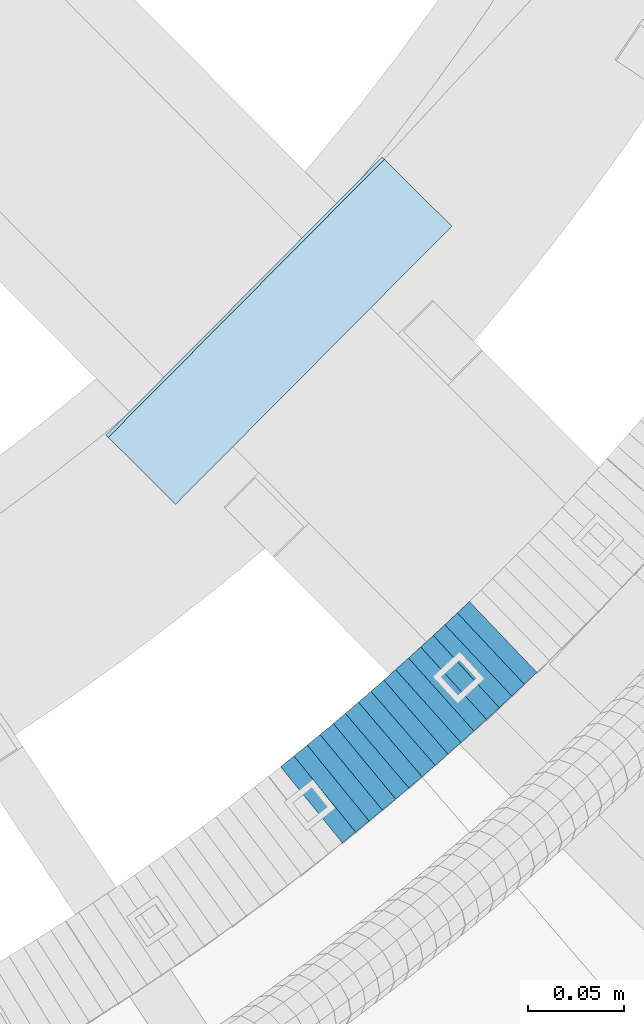
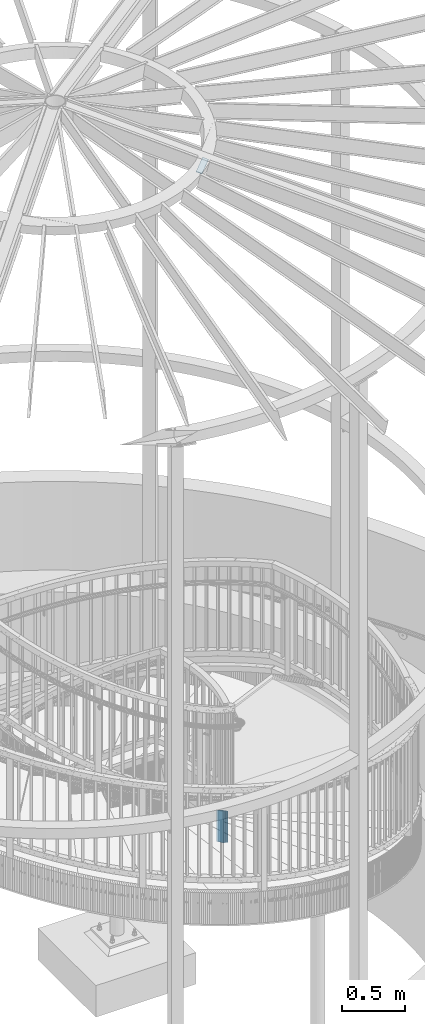
# One storey, part 889 of 975: 16 plates.
"""IFC2X3 building model written with IfcOpenShell, lengths in millimetres."""

import ifcopenshell
import ifcopenshell.guid

model = None  # the IFC model being written
_history = None  # IfcOwnerHistory: only IFC2X3 demands one
_inside = {}  # id of a spatial element -> (the spatial element, [elements in it])
_under = {}  # id of a project, library or spatial element -> (it, [spatial elements below it])
_declared = {}  # id of a project -> (the project, [libraries it declares])
_typed = {}  # id of a type object -> (the type object, [elements of that type])
_made_of = {}  # id of a material, layer set ... -> (it, [elements and type objects made of it])


def new_model(schema):
    """Start an empty IFC model of exactly this schema.

    Asked for "IFC4X3", IfcOpenShell would pick the latest addendum, in which some entities
    have other attributes; the version numbers below select the first issue.
    IFC2X3 requires an IfcOwnerHistory on every rooted entity: one is made here for all.
    """
    global model, _history
    if schema == "IFC4X3":
        model = ifcopenshell.file(schema_version=(4, 3, 0, 0))
    else:
        model = ifcopenshell.file(schema=schema)
    _inside.clear()
    _under.clear()
    _declared.clear()
    _typed.clear()
    _made_of.clear()
    _history = None
    if model.schema == "IFC2X3":
        org = make("IfcOrganization", Name="unknown")
        user = make(
            "IfcPersonAndOrganization",
            ThePerson=make("IfcPerson", FamilyName="unknown"),
            TheOrganization=org,
        )
        app = make(
            "IfcApplication",
            ApplicationDeveloper=org,
            Version="unknown",
            ApplicationFullName="unknown",
            ApplicationIdentifier="unknown",
        )
        _history = make(
            "IfcOwnerHistory",
            OwningUser=user,
            OwningApplication=app,
            ChangeAction="ADDED",
            CreationDate=0,
        )
    return model


def make(cls, **values):
    """One entity of the class cls with the attributes given. An attribute that is None is left unset."""
    return model.create_entity(
        cls, **{name: value for name, value in values.items() if value is not None}
    )


def rooted(cls, **values):
    """An entity with a GlobalId (a new one), such as an element, a storey or a relation."""
    return make(cls, GlobalId=ifcopenshell.guid.new(), OwnerHistory=_history, **values)


def si_unit(unit_type, name, prefix=None):
    """IfcSIUnit, for example si_unit("LENGTHUNIT", "METRE", prefix="MILLI")."""
    return make("IfcSIUnit", UnitType=unit_type, Prefix=prefix, Name=name)


def assignment(units):
    """IfcUnitAssignment: the units of a project."""
    return None if units is None else make("IfcUnitAssignment", Units=units)


def point(xyz):
    """IfcCartesianPoint."""
    return None if xyz is None else make("IfcCartesianPoint", Coordinates=xyz)


def direction(xyz):
    """IfcDirection."""
    return None if xyz is None else make("IfcDirection", DirectionRatios=xyz)


def frame(location, z_axis=None, x_axis=None):
    """IfcAxis2Placement3D, a coordinate frame: its origin and axes. An axis left out is left unset."""
    return make(
        "IfcAxis2Placement3D",
        Location=point(location),
        Axis=direction(z_axis),
        RefDirection=direction(x_axis),
    )


def origin_with_axes():
    """The frame at (0, 0, 0) with the z axis (0, 0, 1) and the x axis (1, 0, 0) written out."""
    return frame((0.0, 0.0, 0.0), z_axis=(0.0, 0.0, 1.0), x_axis=(1.0, 0.0, 0.0))


def place(relative_to, where):
    """IfcLocalPlacement: puts the frame where relative to a parent placement (None: the world)."""
    return make(
        "IfcLocalPlacement", PlacementRelTo=relative_to, RelativePlacement=where
    )


def context(
    kind, dimensions, precision=None, world=None, true_north=None, identifier=None
):
    """IfcGeometricRepresentationContext, for example the 3D "Model" context."""
    return make(
        "IfcGeometricRepresentationContext",
        ContextIdentifier=identifier,
        ContextType=kind,
        CoordinateSpaceDimension=dimensions,
        Precision=precision,
        WorldCoordinateSystem=world,
        TrueNorth=true_north,
    )


def subcontext(parent, identifier, kind, view, scale=None):
    """IfcGeometricRepresentationSubContext, for example "Body" below "Model"."""
    return make(
        "IfcGeometricRepresentationSubContext",
        ContextIdentifier=identifier,
        ContextType=kind,
        ParentContext=parent,
        TargetScale=scale,
        TargetView=view,
    )


def project(units=None, contexts=None):
    """IfcProject with its units and contexts."""
    return rooted(
        "IfcProject",
        Name="project",
        RepresentationContexts=contexts,
        UnitsInContext=assignment(units),
    )


def spatial(cls, under=None, at=None, **own):
    """A site, building, storey or space (cls), placed at a placement, below another one or the project."""
    s = rooted(cls, ObjectPlacement=at, **own)
    if under is not None:
        _under.setdefault(under.id(), (under, []))[1].append(s)
    return s


def faces_of(points, faces, orient=None, outer=None):
    """IfcFace entities. A face is a list of loops; a loop is a list of indices into points, from 0.

    orient and outer hold one flag for each loop. By default every Orientation is true, the
    first loop of a face is its IfcFaceOuterBound and the others are IfcFaceBound.
    """
    made = []
    for i, loops in enumerate(faces):
        bounds = []
        for j, loop in enumerate(loops):
            is_outer = j == 0 if outer is None else outer[i][j]
            bounds.append(
                make(
                    "IfcFaceOuterBound" if is_outer else "IfcFaceBound",
                    Bound=make("IfcPolyLoop", Polygon=[points[k] for k in loop]),
                    Orientation=True if orient is None else orient[i][j],
                )
            )
        made.append(make("IfcFace", Bounds=bounds))
    return made


def faceted_brep(points, faces, orient=None, outer=None, voids=None):
    """IfcFacetedBrep: a solid bounded by flat faces; with voids (closed shells), ...WithVoids."""
    shared = [point(p) for p in points]
    hull = make("IfcClosedShell", CfsFaces=faces_of(shared, faces, orient, outer))
    if voids is None:
        return make("IfcFacetedBrep", Outer=hull)
    return make(
        "IfcFacetedBrepWithVoids",
        Outer=hull,
        Voids=[
            make(cls, CfsFaces=faces_of(shared, fs, o, b)) for cls, fs, o, b in voids
        ],
    )


def shape(context_of_items, identifier, shape_type, items):
    """IfcShapeRepresentation: the items that make up one representation, for example the "Body"."""
    return make(
        "IfcShapeRepresentation",
        ContextOfItems=context_of_items,
        RepresentationIdentifier=identifier,
        RepresentationType=shape_type,
        Items=items,
    )


def material(Name=None, Category=None):
    """IfcMaterial."""
    return make("IfcMaterial", Name=Name, Category=Category)


def made_of(thing, what):
    """Note that an element or type object is made of a material, layer set ...; save() writes the relation."""
    if what is not None:
        _made_of.setdefault(what.id(), (what, []))[1].append(thing)
    return thing


def type_object(cls, material=None, **own):
    """A type object (cls), such as IfcWallType, which elements share."""
    return made_of(rooted(cls, **own), material)


def element(
    cls,
    number,
    at=None,
    inside=None,
    cuts=None,
    type_object=None,
    material=None,
    context=None,
    identifier="Body",
    shape_type=None,
    held_by="IfcProductDefinitionShape",
    body=None,
    shapes=None,
    **own,
):
    """One element of the class cls, such as IfcWall. Its Tag is "e" and its number.

    at: its placement. inside: the storey or other place that contains it. cuts: it is an
    opening in that element (IfcRelVoidsElement). A single representation is given by context,
    identifier, shape_type and body (its items); several are given by shapes. held_by: the class
    of the entity that holds the representations. save() writes the other relations.
    """
    e = rooted(cls, Tag="e%d" % number, ObjectPlacement=at, **own)
    if body is not None:
        shapes = [shape(context, identifier, shape_type, body)]
    if shapes is not None:
        e.Representation = make(held_by, Representations=shapes)
    if inside is not None:
        _inside.setdefault(inside.id(), (inside, []))[1].append(e)
    if cuts is not None:
        rooted(
            "IfcRelVoidsElement", RelatingBuildingElement=cuts, RelatedOpeningElement=e
        )
    if type_object is not None:
        _typed.setdefault(type_object.id(), (type_object, []))[1].append(e)
    return made_of(e, material)


def aggregate(whole, parts):
    """IfcRelAggregates: a whole, such as a stair, and the parts it consists of."""
    return rooted("IfcRelAggregates", RelatingObject=whole, RelatedObjects=parts)


def save(model, path):
    """Write the relations noted so far, then the file.

    IfcRelAggregates (storeys below a building ...), IfcRelContainedInSpatialStructure (elements
    in a storey), IfcRelDefinesByType, IfcRelAssociatesMaterial and IfcRelDeclares: one each for
    every whole, place, type object, material and project.
    """
    for whole, parts in _under.values():
        aggregate(whole, parts)
    for where, things in _inside.values():
        rooted(
            "IfcRelContainedInSpatialStructure",
            RelatedElements=things,
            RelatingStructure=where,
        )
    for kind, things in _typed.values():
        rooted("IfcRelDefinesByType", RelatedObjects=things, RelatingType=kind)
    for what, things in _made_of.values():
        rooted("IfcRelAssociatesMaterial", RelatedObjects=things, RelatingMaterial=what)
    for by, libraries in _declared.values():
        rooted("IfcRelDeclares", RelatingContext=by, RelatedDefinitions=libraries)
    model.write(path)


model = new_model("IFC2X3")

# Units and contexts
model_context = context("Model", 3, precision=1e-05, world=origin_with_axes())
body_context = subcontext(model_context, "Body", "Model", "MODEL_VIEW")
ifc_project = project(units=[si_unit("LENGTHUNIT", "METRE", prefix="MILLI"), si_unit("AREAUNIT", "SQUARE_METRE"), si_unit("VOLUMEUNIT", "CUBIC_METRE"), si_unit("MASSUNIT", "GRAM", prefix="KILO"), si_unit("TIMEUNIT", "SECOND"), si_unit("PLANEANGLEUNIT", "RADIAN"), si_unit("SOLIDANGLEUNIT", "STERADIAN"), si_unit("THERMODYNAMICTEMPERATUREUNIT", "DEGREE_CELSIUS"), si_unit("LUMINOUSINTENSITYUNIT", "LUMEN")], contexts=[model_context])

# Site, building, storey
site_placement = place(None, origin_with_axes())
site = spatial("IfcSite", under=ifc_project, at=site_placement, CompositionType="ELEMENT")
building_placement = place(site_placement, origin_with_axes())
building = spatial("IfcBuilding", under=site, at=building_placement, Name="Undefined", CompositionType="ELEMENT")
storey_placement = place(building_placement, origin_with_axes())
storey = spatial("IfcBuildingStorey", under=building, at=storey_placement, Name="Undefined", CompositionType="ELEMENT", Elevation=0.0)

# Plates
ifc_material = material(Name="STEEL/A36")
plate_type_1 = type_object("IfcPlateType", PredefinedType="NOTDEFINED")
plate_1_placement = place(storey_placement, frame((35611.4589411567, 2315.99596524188, 2451.22500005033), z_axis=(-0.776458094333385, -0.630168888270572, 0.0), x_axis=(0.0, 0.0, 1.0)))
element("IfcPlate", 1, at=plate_1_placement, inside=storey, type_object=plate_type_1, material=ifc_material, Name="WALL", context=body_context, shape_type="Brep", body=[
    faceted_brep([(0.0, -25.3999999999724, -1.81898940354586e-11), (5.80000019073486, -25.4000000000597, 8.88650703423627), (5.80000019073486, 25.400000000056, 8.8865070343636), (0.0, 25.3999999999869, 1.45519152283669e-11), (310.600006103516, -25.4000000000597, 8.88650703423627), (310.600006103516, 25.400000000056, 8.8865070343636), (304.799987792969, -25.3999999999724, -1.81898940354586e-11), (304.799987792969, 25.3999999999869, 1.45519152283669e-11)], [[[0, 1, 2, 3]], [[1, 4, 5, 2]], [[4, 6, 7, 5]], [[6, 0, 3, 7]], [[5, 7, 3, 2]], [[6, 4, 1, 0]]]),
])
plate_2_placement = place(storey_placement, frame((35618.4270018012, 2321.6700004936, 2445.52500005033), z_axis=(-0.77543586015187, -0.631426343123669, 0.0), x_axis=(0.0, 0.0, 1.0)))
element("IfcPlate", 2, at=plate_2_placement, inside=storey, type_object=plate_type_1, material=ifc_material, Name="WALL", context=body_context, shape_type="Brep", body=[
    faceted_brep([(0.0, -25.3999999999724, -1.81898940354586e-11), (5.69999980926514, -25.3999999999901, 9.02718162541714), (5.69999980926514, 25.3999999999951, 9.02718162535166), (0.0, 25.3999999999869, 1.45519152283669e-11), (310.5, -25.3999999999901, 9.02718162541714), (310.5, 25.3999999999951, 9.02718162535166), (304.799987792969, -25.3999999999724, -1.81898940354586e-11), (304.799987792969, 25.3999999999869, 1.45519152283669e-11)], [[[0, 1, 2, 3]], [[1, 4, 5, 2]], [[4, 6, 7, 5]], [[6, 0, 3, 7]], [[5, 7, 3, 2]], [[6, 4, 1, 0]]]),
])
plate_3_placement = place(storey_placement, frame((35625.1884421676, 2327.25635814104, 2439.72500005033), z_axis=(-0.770961751776529, -0.636881446815391, 0.0), x_axis=(0.0, 0.0, 1.0)))
element("IfcPlate", 3, at=plate_3_placement, inside=storey, type_object=plate_type_1, material=ifc_material, Name="WALL", context=body_context, shape_type="Brep", body=[
    faceted_brep([(0.0, -25.3999999999724, -1.81898940354586e-11), (5.80000019073486, -25.3999999999942, 8.94930171964734), (5.80000019073486, 25.4000000000015, 8.94930171966917), (0.0, 25.3999999999869, 1.45519152283669e-11), (310.600006103516, -25.3999999999942, 8.94930171964734), (310.600006103516, 25.4000000000015, 8.94930171966917), (304.799987792969, -25.3999999999724, -1.81898940354586e-11), (304.799987792969, 25.3999999999869, 1.45519152283669e-11)], [[[0, 1, 2, 3]], [[1, 4, 5, 2]], [[4, 6, 7, 5]], [[6, 0, 3, 7]], [[5, 7, 3, 2]], [[6, 4, 1, 0]]]),
])
plate_4_placement = place(storey_placement, frame((35632.0884421659, 2332.9563581411, 2434.02500005033), z_axis=(-0.770961751776529, -0.636881446815391, 0.0), x_axis=(0.0, 0.0, 1.0)))
element("IfcPlate", 4, at=plate_4_placement, inside=storey, type_object=plate_type_1, material=ifc_material, Name="WALL", context=body_context, shape_type="Brep", body=[
    faceted_brep([(0.0, -25.3999999999724, -1.81898940354586e-11), (5.69999980926514, -25.3999999999869, 8.94930171964734), (5.69999980926514, 25.4000000000051, 8.94930171966917), (0.0, 25.3999999999869, 1.45519152283669e-11), (310.5, -25.3999999999869, 8.94930171964734), (310.5, 25.4000000000051, 8.94930171966917), (304.799987792969, -25.3999999999724, -1.81898940354586e-11), (304.799987792969, 25.3999999999869, 1.45519152283669e-11)], [[[0, 1, 2, 3]], [[1, 4, 5, 2]], [[4, 6, 7, 5]], [[6, 0, 3, 7]], [[5, 7, 3, 2]], [[6, 4, 1, 0]]]),
])
plate_5_placement = place(storey_placement, frame((35638.5819871232, 2338.49911202704, 2428.22500005033), z_axis=(-0.760833952017173, -0.648946606014648, 0.0), x_axis=(0.0, 0.0, 1.0)))
element("IfcPlate", 5, at=plate_5_placement, inside=storey, type_object=plate_type_1, material=ifc_material, Name="WALL", context=body_context, shape_type="Brep", body=[
    faceted_brep([(0.0, -25.3999999999724, -1.81898940354586e-11), (5.80000019073486, -25.4000000000087, 8.9375610351708), (5.80000019073486, 25.400000000016, 8.93756103512715), (0.0, 25.3999999999869, 1.45519152283669e-11), (310.600006103516, -25.4000000000087, 8.9375610351708), (310.600006103516, 25.400000000016, 8.93756103512715), (304.799987792969, -25.3999999999724, -1.81898940354586e-11), (304.799987792969, 25.3999999999869, 1.45519152283669e-11)], [[[0, 1, 2, 3]], [[1, 4, 5, 2]], [[4, 6, 7, 5]], [[6, 0, 3, 7]], [[5, 7, 3, 2]], [[6, 4, 1, 0]]]),
])
plate_6_placement = place(storey_placement, frame((35645.381987124, 2344.29911202725, 2422.52500005033), z_axis=(-0.760833952017173, -0.648946606014648, 0.0), x_axis=(0.0, 0.0, 1.0)))
element("IfcPlate", 6, at=plate_6_placement, inside=storey, type_object=plate_type_1, material=ifc_material, Name="WALL", context=body_context, shape_type="Brep", body=[
    faceted_brep([(0.0, -25.3999999999724, -1.81898940354586e-11), (5.69999980926514, -25.4000000000851, 8.94035816198448), (5.69999980926514, 25.4000000000524, 8.94035816188989), (0.0, 25.3999999999869, 1.45519152283669e-11), (310.5, -25.4000000000851, 8.94035816198448), (310.5, 25.4000000000524, 8.94035816188989), (304.799987792969, -25.3999999999724, -1.81898940354586e-11), (304.799987792969, 25.3999999999869, 1.45519152283669e-11)], [[[0, 1, 2, 3]], [[1, 4, 5, 2]], [[4, 6, 7, 5]], [[6, 0, 3, 7]], [[5, 7, 3, 2]], [[6, 4, 1, 0]]]),
])
plate_7_placement = place(storey_placement, frame((35652.0192566585, 2350.05912031496, 2416.82500005033), z_axis=(-0.755322467280274, -0.655353317243179, 0.0), x_axis=(0.0, 0.0, 1.0)))
element("IfcPlate", 7, at=plate_7_placement, inside=storey, type_object=plate_type_1, material=ifc_material, Name="WALL", context=body_context, shape_type="Brep", body=[
    faceted_brep([(0.0, -25.3999999999724, -1.81898940354586e-11), (5.69999980926514, -25.3999999999978, 9.00277709959482), (5.69999980926514, 25.3999999999651, 9.00277709966031), (0.0, 25.3999999999869, 1.45519152283669e-11), (310.5, -25.3999999999978, 9.00277709959482), (310.5, 25.3999999999651, 9.00277709966031), (304.799987792969, -25.3999999999724, -1.81898940354586e-11), (304.799987792969, 25.3999999999869, 1.45519152283669e-11)], [[[0, 1, 2, 3]], [[1, 4, 5, 2]], [[4, 6, 7, 5]], [[6, 0, 3, 7]], [[5, 7, 3, 2]], [[6, 4, 1, 0]]]),
])
plate_8_placement = place(storey_placement, frame((35658.7409100936, 2355.87788645664, 2411.02500005033), z_axis=(-0.756061291757536, -0.65450081979011, 0.0), x_axis=(0.0, 0.0, 1.0)))
element("IfcPlate", 8, at=plate_8_placement, inside=storey, type_object=plate_type_1, material=ifc_material, Name="WALL", context=body_context, shape_type="Brep", body=[
    faceted_brep([(0.0, -25.3999999999724, -1.81898940354586e-11), (5.80000019073486, -25.4000000000106, 8.86171531681612), (5.80000019073486, 25.4000000000015, 8.86171531675791), (0.0, 25.3999999999869, 1.45519152283669e-11), (310.600006103516, -25.4000000000106, 8.86171531681612), (310.600006103516, 25.4000000000015, 8.86171531675791), (304.799987792969, -25.3999999999724, -1.81898940354586e-11), (304.799987792969, 25.3999999999869, 1.45519152283669e-11)], [[[0, 1, 2, 3]], [[1, 4, 5, 2]], [[4, 6, 7, 5]], [[6, 0, 3, 7]], [[5, 7, 3, 2]], [[6, 4, 1, 0]]]),
])
plate_9_placement = place(storey_placement, frame((35665.1203879181, 2361.59567099939, 2405.32500005033), z_axis=(-0.744950446985006, -0.667119802986569, 0.0), x_axis=(0.0, 0.0, 1.0)))
element("IfcPlate", 9, at=plate_9_placement, inside=storey, type_object=plate_type_1, material=ifc_material, Name="WALL", context=body_context, shape_type="Brep", body=[
    faceted_brep([(0.0, -25.3999999999724, -1.81898940354586e-11), (5.69999980926514, -25.4000000000196, 8.98721313477654), (5.69999980926514, 25.4000000000669, 8.98721313470742), (0.0, 25.3999999999869, 1.45519152283669e-11), (310.5, -25.4000000000196, 8.98721313477654), (310.5, 25.4000000000669, 8.98721313470742), (304.799987792969, -25.3999999999724, -1.81898940354586e-11), (304.799987792969, 25.3999999999869, 1.45519152283669e-11)], [[[0, 1, 2, 3]], [[1, 4, 5, 2]], [[4, 6, 7, 5]], [[6, 0, 3, 7]], [[5, 7, 3, 2]], [[6, 4, 1, 0]]]),
])
plate_10_placement = place(storey_placement, frame((35671.8203879207, 2367.59567099939, 2399.52500005033), z_axis=(-0.744950446985006, -0.667119802986569, 0.0), x_axis=(0.0, 0.0, 1.0)))
element("IfcPlate", 10, at=plate_10_placement, inside=storey, type_object=plate_type_1, material=ifc_material, Name="WALL", context=body_context, shape_type="Brep", body=[
    faceted_brep([(0.0, -25.3999999999724, -1.81898940354586e-11), (5.80000019073486, -25.4000000000815, 8.99388694768095), (5.80000019073486, 25.4000000000342, 8.99388694761365), (0.0, 25.3999999999869, 1.45519152283669e-11), (310.600006103516, -25.4000000000815, 8.99388694768095), (310.600006103516, 25.4000000000342, 8.99388694761365), (304.799987792969, -25.3999999999724, -1.81898940354586e-11), (304.799987792969, 25.3999999999869, 1.45519152283669e-11)], [[[0, 1, 2, 3]], [[1, 4, 5, 2]], [[4, 6, 7, 5]], [[6, 0, 3, 7]], [[5, 7, 3, 2]], [[6, 4, 1, 0]]]),
])
plate_11_placement = place(storey_placement, frame((35678.2793419449, 2373.46840750578, 2393.82500005033), z_axis=(-0.739940073214946, -0.67267279419541, 0.0), x_axis=(0.0, 0.0, 1.0)))
element("IfcPlate", 11, at=plate_11_placement, inside=storey, type_object=plate_type_1, material=ifc_material, Name="WALL", context=body_context, shape_type="Brep", body=[
    faceted_brep([(0.0, -25.3999999999724, -1.81898940354586e-11), (5.69999980926514, -25.4000000000269, 8.9196414947728), (5.69999980926514, 25.3999999999796, 8.91964149476189), (0.0, 25.3999999999869, 1.45519152283669e-11), (310.5, -25.4000000000269, 8.9196414947728), (310.5, 25.3999999999796, 8.91964149476189), (304.799987792969, -25.3999999999724, -1.81898940354586e-11), (304.799987792969, 25.3999999999869, 1.45519152283669e-11)], [[[0, 1, 2, 3]], [[1, 4, 5, 2]], [[4, 6, 7, 5]], [[6, 0, 3, 7]], [[5, 7, 3, 2]], [[6, 4, 1, 0]]]),
])
plate_12_placement = place(storey_placement, frame((35684.8793419457, 2379.46840750585, 2388.02500005033), z_axis=(-0.739940073214946, -0.67267279419541, 0.0), x_axis=(0.0, 0.0, 1.0)))
element("IfcPlate", 12, at=plate_12_placement, inside=storey, type_object=plate_type_1, material=ifc_material, Name="WALL", context=body_context, shape_type="Brep", body=[
    faceted_brep([(0.0, -25.3999999999724, -1.81898940354586e-11), (5.80000019073486, -25.3999999999633, 8.91964149466003), (5.80000019073486, 25.3999999999669, 8.91964149481646), (0.0, 25.3999999999869, 1.45519152283669e-11), (310.600006103516, -25.3999999999633, 8.91964149466003), (310.600006103516, 25.3999999999669, 8.91964149481646), (304.799987792969, -25.3999999999724, -1.81898940354586e-11), (304.799987792969, 25.3999999999869, 1.45519152283669e-11)], [[[0, 1, 2, 3]], [[1, 4, 5, 2]], [[4, 6, 7, 5]], [[6, 0, 3, 7]], [[5, 7, 3, 2]], [[6, 4, 1, 0]]]),
])
for number, where, z_axis, x_axis, name in (
    (13, (35691.0836501402, 2385.29528622666, 2382.32500005033), (-0.729187266944916, -0.684314203948306, 0.0), (0.0, 0.0, 1.0), "WALL"),
    (14, (35697.5836501424, 2391.39528622681, 2376.62500005033), (-0.729187266944916, -0.684314203948306, 0.0), (0.0, 0.0, 1.0), "WALL"),
):
    element("IfcPlate", number, at=place(storey_placement, frame(where, z_axis=z_axis, x_axis=x_axis)), inside=storey, type_object=plate_type_1, material=ifc_material, Name=name, context=body_context, shape_type="Brep", body=[
        faceted_brep([(0.0, -25.3999999999724, -1.81898940354586e-11), (5.69999980926514, -25.4000000000269, 8.91066741947361), (5.69999980926514, 25.4000000000269, 8.91066741941904), (0.0, 25.3999999999869, 1.45519152283669e-11), (310.5, -25.4000000000269, 8.91066741947361), (310.5, 25.4000000000269, 8.91066741941904), (304.799987792969, -25.3999999999724, -1.81898940354586e-11), (304.799987792969, 25.3999999999869, 1.45519152283669e-11)], [[[0, 1, 2, 3]], [[1, 4, 5, 2]], [[4, 6, 7, 5]], [[6, 0, 3, 7]], [[5, 7, 3, 2]], [[6, 4, 1, 0]]]),
    ])
plate_13_placement = place(storey_placement, frame((35703.9338733255, 2397.45357873987, 2370.82500005033), z_axis=(-0.723608232025611, -0.690210929024432, 0.0), x_axis=(0.0, 0.0, 1.0)))
element("IfcPlate", 15, at=plate_13_placement, inside=storey, type_object=plate_type_1, material=ifc_material, Name="WALL", context=body_context, shape_type="Brep", body=[
    faceted_brep([(0.0, -25.3999999999724, -1.81898940354586e-11), (5.80000019073486, -25.3999999999432, 8.98109149925949), (5.80000019073486, 25.3999999999651, 8.98109149937954), (0.0, 25.3999999999869, 1.45519152283669e-11), (310.600006103516, -25.3999999999432, 8.98109149925949), (310.600006103516, 25.3999999999651, 8.98109149937954), (304.799987792969, -25.3999999999724, -1.81898940354586e-11), (304.799987792969, 25.3999999999869, 1.45519152283669e-11)], [[[0, 1, 2, 3]], [[1, 4, 5, 2]], [[4, 6, 7, 5]], [[6, 0, 3, 7]], [[5, 7, 3, 2]], [[6, 4, 1, 0]]]),
])
plate_type_2 = type_object("IfcPlateType", PredefinedType="NOTDEFINED")
plate_14_placement = place(storey_placement, frame((35676.7839836258, 2610.9624584938, 8843.5048341401), z_axis=(-0.688502112820797, 0.683475127155155, 0.242541936995531), x_axis=(-0.704511181200147, -0.709692888201632, 9.99996585989336e-10)))
element("IfcPlate", 16, at=plate_14_placement, inside=storey, type_object=plate_type_2, material=ifc_material, Name="PLATE", context=body_context, shape_type="Brep", body=[
    faceted_brep([(0.0, -3.17499999999927, 0.0), (0.0, -3.17500000000882, 50.7999992370605), (0.0, 3.17499999999109, 50.7999992370678), (0.0, 3.17499999999927, 0.0), (203.199996947696, -3.17500000024665, 50.7999992364676), (203.1999969477, 3.17499999975553, 50.7999992364748), (203.199996947791, -3.17500000022483, -3.56521923094988e-10), (203.199996947806, 3.17499999978281, -3.41970007866621e-10)], [[[0, 1, 2, 3]], [[1, 4, 5, 2]], [[4, 6, 7, 5]], [[6, 0, 3, 7]], [[5, 7, 3, 2]], [[6, 4, 1, 0]]]),
])

save(model, "model.ifc")
